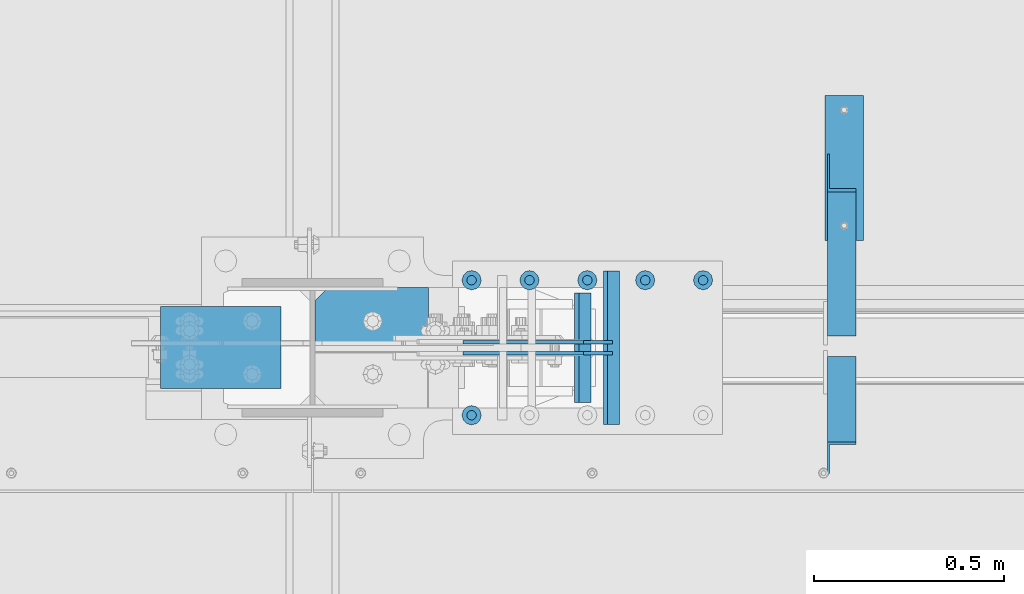
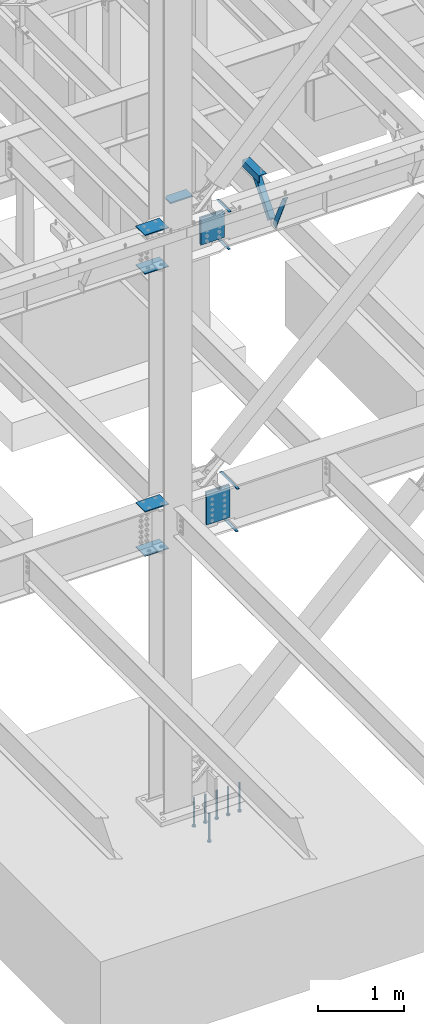
# One storey, part 835 of 1179: 20 beams, 2 members, 11 elements without a shape of their own.
"""IFC2X3 building model written with IfcOpenShell, lengths in millimetres."""

import ifcopenshell
import ifcopenshell.guid

model = None  # the IFC model being written
_history = None  # IfcOwnerHistory: only IFC2X3 demands one
_inside = {}  # id of a spatial element -> (the spatial element, [elements in it])
_under = {}  # id of a project, library or spatial element -> (it, [spatial elements below it])
_declared = {}  # id of a project -> (the project, [libraries it declares])
_typed = {}  # id of a type object -> (the type object, [elements of that type])
_made_of = {}  # id of a material, layer set ... -> (it, [elements and type objects made of it])


def new_model(schema):
    """Start an empty IFC model of exactly this schema.

    Asked for "IFC4X3", IfcOpenShell would pick the latest addendum, in which some entities
    have other attributes; the version numbers below select the first issue.
    IFC2X3 requires an IfcOwnerHistory on every rooted entity: one is made here for all.
    """
    global model, _history
    if schema == "IFC4X3":
        model = ifcopenshell.file(schema_version=(4, 3, 0, 0))
    else:
        model = ifcopenshell.file(schema=schema)
    _inside.clear()
    _under.clear()
    _declared.clear()
    _typed.clear()
    _made_of.clear()
    _history = None
    if model.schema == "IFC2X3":
        org = make("IfcOrganization", Name="unknown")
        user = make(
            "IfcPersonAndOrganization",
            ThePerson=make("IfcPerson", FamilyName="unknown"),
            TheOrganization=org,
        )
        app = make(
            "IfcApplication",
            ApplicationDeveloper=org,
            Version="unknown",
            ApplicationFullName="unknown",
            ApplicationIdentifier="unknown",
        )
        _history = make(
            "IfcOwnerHistory",
            OwningUser=user,
            OwningApplication=app,
            ChangeAction="ADDED",
            CreationDate=0,
        )
    return model


def make(cls, **values):
    """One entity of the class cls with the attributes given. An attribute that is None is left unset."""
    return model.create_entity(
        cls, **{name: value for name, value in values.items() if value is not None}
    )


def rooted(cls, **values):
    """An entity with a GlobalId (a new one), such as an element, a storey or a relation."""
    return make(cls, GlobalId=ifcopenshell.guid.new(), OwnerHistory=_history, **values)


def si_unit(unit_type, name, prefix=None):
    """IfcSIUnit, for example si_unit("LENGTHUNIT", "METRE", prefix="MILLI")."""
    return make("IfcSIUnit", UnitType=unit_type, Prefix=prefix, Name=name)


def assignment(units):
    """IfcUnitAssignment: the units of a project."""
    return None if units is None else make("IfcUnitAssignment", Units=units)


def point(xyz):
    """IfcCartesianPoint."""
    return None if xyz is None else make("IfcCartesianPoint", Coordinates=xyz)


def direction(xyz):
    """IfcDirection."""
    return None if xyz is None else make("IfcDirection", DirectionRatios=xyz)


def frame(location, z_axis=None, x_axis=None):
    """IfcAxis2Placement3D, a coordinate frame: its origin and axes. An axis left out is left unset."""
    return make(
        "IfcAxis2Placement3D",
        Location=point(location),
        Axis=direction(z_axis),
        RefDirection=direction(x_axis),
    )


def origin_with_axes():
    """The frame at (0, 0, 0) with the z axis (0, 0, 1) and the x axis (1, 0, 0) written out."""
    return frame((0.0, 0.0, 0.0), z_axis=(0.0, 0.0, 1.0), x_axis=(1.0, 0.0, 0.0))


def place(relative_to, where):
    """IfcLocalPlacement: puts the frame where relative to a parent placement (None: the world)."""
    return make(
        "IfcLocalPlacement", PlacementRelTo=relative_to, RelativePlacement=where
    )


def context(
    kind, dimensions, precision=None, world=None, true_north=None, identifier=None
):
    """IfcGeometricRepresentationContext, for example the 3D "Model" context."""
    return make(
        "IfcGeometricRepresentationContext",
        ContextIdentifier=identifier,
        ContextType=kind,
        CoordinateSpaceDimension=dimensions,
        Precision=precision,
        WorldCoordinateSystem=world,
        TrueNorth=true_north,
    )


def subcontext(parent, identifier, kind, view, scale=None):
    """IfcGeometricRepresentationSubContext, for example "Body" below "Model"."""
    return make(
        "IfcGeometricRepresentationSubContext",
        ContextIdentifier=identifier,
        ContextType=kind,
        ParentContext=parent,
        TargetScale=scale,
        TargetView=view,
    )


def project(units=None, contexts=None):
    """IfcProject with its units and contexts."""
    return rooted(
        "IfcProject",
        Name="project",
        RepresentationContexts=contexts,
        UnitsInContext=assignment(units),
    )


def spatial(cls, under=None, at=None, **own):
    """A site, building, storey or space (cls), placed at a placement, below another one or the project."""
    s = rooted(cls, ObjectPlacement=at, **own)
    if under is not None:
        _under.setdefault(under.id(), (under, []))[1].append(s)
    return s


def faces_of(points, faces, orient=None, outer=None):
    """IfcFace entities. A face is a list of loops; a loop is a list of indices into points, from 0.

    orient and outer hold one flag for each loop. By default every Orientation is true, the
    first loop of a face is its IfcFaceOuterBound and the others are IfcFaceBound.
    """
    made = []
    for i, loops in enumerate(faces):
        bounds = []
        for j, loop in enumerate(loops):
            is_outer = j == 0 if outer is None else outer[i][j]
            bounds.append(
                make(
                    "IfcFaceOuterBound" if is_outer else "IfcFaceBound",
                    Bound=make("IfcPolyLoop", Polygon=[points[k] for k in loop]),
                    Orientation=True if orient is None else orient[i][j],
                )
            )
        made.append(make("IfcFace", Bounds=bounds))
    return made


def faceted_brep(points, faces, orient=None, outer=None, voids=None):
    """IfcFacetedBrep: a solid bounded by flat faces; with voids (closed shells), ...WithVoids."""
    shared = [point(p) for p in points]
    hull = make("IfcClosedShell", CfsFaces=faces_of(shared, faces, orient, outer))
    if voids is None:
        return make("IfcFacetedBrep", Outer=hull)
    return make(
        "IfcFacetedBrepWithVoids",
        Outer=hull,
        Voids=[
            make(cls, CfsFaces=faces_of(shared, fs, o, b)) for cls, fs, o, b in voids
        ],
    )


def shape(context_of_items, identifier, shape_type, items):
    """IfcShapeRepresentation: the items that make up one representation, for example the "Body"."""
    return make(
        "IfcShapeRepresentation",
        ContextOfItems=context_of_items,
        RepresentationIdentifier=identifier,
        RepresentationType=shape_type,
        Items=items,
    )


def material(Name=None, Category=None):
    """IfcMaterial."""
    return make("IfcMaterial", Name=Name, Category=Category)


def made_of(thing, what):
    """Note that an element or type object is made of a material, layer set ...; save() writes the relation."""
    if what is not None:
        _made_of.setdefault(what.id(), (what, []))[1].append(thing)
    return thing


def type_object(cls, material=None, **own):
    """A type object (cls), such as IfcWallType, which elements share."""
    return made_of(rooted(cls, **own), material)


def element(
    cls,
    number,
    at=None,
    inside=None,
    cuts=None,
    type_object=None,
    material=None,
    context=None,
    identifier="Body",
    shape_type=None,
    held_by="IfcProductDefinitionShape",
    body=None,
    shapes=None,
    **own,
):
    """One element of the class cls, such as IfcWall. Its Tag is "e" and its number.

    at: its placement. inside: the storey or other place that contains it. cuts: it is an
    opening in that element (IfcRelVoidsElement). A single representation is given by context,
    identifier, shape_type and body (its items); several are given by shapes. held_by: the class
    of the entity that holds the representations. save() writes the other relations.
    """
    e = rooted(cls, Tag="e%d" % number, ObjectPlacement=at, **own)
    if body is not None:
        shapes = [shape(context, identifier, shape_type, body)]
    if shapes is not None:
        e.Representation = make(held_by, Representations=shapes)
    if inside is not None:
        _inside.setdefault(inside.id(), (inside, []))[1].append(e)
    if cuts is not None:
        rooted(
            "IfcRelVoidsElement", RelatingBuildingElement=cuts, RelatedOpeningElement=e
        )
    if type_object is not None:
        _typed.setdefault(type_object.id(), (type_object, []))[1].append(e)
    return made_of(e, material)


def aggregate(whole, parts):
    """IfcRelAggregates: a whole, such as a stair, and the parts it consists of."""
    return rooted("IfcRelAggregates", RelatingObject=whole, RelatedObjects=parts)


def save(model, path):
    """Write the relations noted so far, then the file.

    IfcRelAggregates (storeys below a building ...), IfcRelContainedInSpatialStructure (elements
    in a storey), IfcRelDefinesByType, IfcRelAssociatesMaterial and IfcRelDeclares: one each for
    every whole, place, type object, material and project.
    """
    for whole, parts in _under.values():
        aggregate(whole, parts)
    for where, things in _inside.values():
        rooted(
            "IfcRelContainedInSpatialStructure",
            RelatedElements=things,
            RelatingStructure=where,
        )
    for kind, things in _typed.values():
        rooted("IfcRelDefinesByType", RelatedObjects=things, RelatingType=kind)
    for what, things in _made_of.values():
        rooted("IfcRelAssociatesMaterial", RelatedObjects=things, RelatingMaterial=what)
    for by, libraries in _declared.values():
        rooted("IfcRelDeclares", RelatingContext=by, RelatedDefinitions=libraries)
    model.write(path)


model = new_model("IFC2X3")

# Units and contexts
model_context = context("Model", 3, precision=1e-05, world=origin_with_axes())
body_context = subcontext(model_context, "Body", "Model", "MODEL_VIEW")
ifc_project = project(units=[si_unit("LENGTHUNIT", "METRE", prefix="MILLI"), si_unit("AREAUNIT", "SQUARE_METRE"), si_unit("VOLUMEUNIT", "CUBIC_METRE"), si_unit("MASSUNIT", "GRAM", prefix="KILO"), si_unit("TIMEUNIT", "SECOND"), si_unit("PLANEANGLEUNIT", "RADIAN"), si_unit("SOLIDANGLEUNIT", "STERADIAN"), si_unit("THERMODYNAMICTEMPERATUREUNIT", "DEGREE_CELSIUS"), si_unit("LUMINOUSINTENSITYUNIT", "LUMEN")], contexts=[model_context])

# Site, building, storey
site_placement = place(None, origin_with_axes())
site = spatial("IfcSite", under=ifc_project, at=site_placement, CompositionType="ELEMENT")
building_placement = place(site_placement, origin_with_axes())
building = spatial("IfcBuilding", under=site, at=building_placement, Name="Undefined", CompositionType="ELEMENT")
storey_placement = place(building_placement, origin_with_axes())
storey = spatial("IfcBuildingStorey", under=building, at=storey_placement, Name="Undefined", CompositionType="ELEMENT", Elevation=0.0)

# Assembly, member
assembly_1_placement = place(storey_placement, origin_with_axes())
assembly_1 = element("IfcElementAssembly", 1, at=assembly_1_placement, inside=storey, Name="ANGLE", AssemblyPlace="NOTDEFINED", PredefinedType="RIGID_FRAME")
ifc_material_1 = material(Name="STEEL/A36")
member_type = type_object("IfcMemberType", Name="L3X3X1/4", PredefinedType="NOTDEFINED")
member_1_placement = place(assembly_1_placement, frame((9674.225, 27524.471875, 8013.7), z_axis=(0.0, 0.767781968046096, -0.640711206038465), x_axis=(0.0, -0.640711206038465, -0.767781968046095)))
member_1 = element("IfcMember", 2, at=member_1_placement, type_object=member_type, material=ifc_material_1, Name="ANGLE", ObjectType="L3X3X1/4", context=body_context, shape_type="Brep", body=[
    faceted_brep([(52.4707516281596, 38.1000000000004, -38.0999999999731), (-11.1178658854478, 38.1000000000004, 38.1000000000131), (644.538058171762, 38.1000000000004, 38.1000000006206), (644.538058171769, 38.1000000000004, -38.0999999994237), (-11.1178658854478, 31.75, 38.1000000000131), (644.538058171762, 31.75, 38.1000000006206), (47.171700168692, 31.75, -31.7499999999764), (644.538058171769, 31.75, -31.7499999994234), (47.171700168692, -38.1000000000004, -31.7499999999764), (644.538058171769, -38.1000000000004, -31.7499999994234), (52.4707516281596, -38.1000000000004, -38.0999999999731), (644.538058171769, -38.1000000000004, -38.0999999994237)], [[[0, 1, 2, 3]], [[1, 4, 5, 2]], [[4, 6, 7, 5]], [[6, 8, 9, 7]], [[8, 10, 11, 9]], [[10, 0, 3, 11]], [[5, 7, 9, 11, 3, 2]], [[10, 8, 6, 4, 1, 0]]]),
])
aggregate(assembly_1, [member_1])

assembly_2_placement = place(storey_placement, origin_with_axes())
assembly_2 = element("IfcElementAssembly", 3, at=assembly_2_placement, inside=storey, Name="ANGLE", AssemblyPlace="NOTDEFINED", PredefinedType="RIGID_FRAME")
member_2_placement = place(assembly_2_placement, frame((9674.225, 26993.5873387815, 7510.54092786574), z_axis=(0.0, -0.907857849951123, -0.419278098977426), x_axis=(0.0, -0.419278098977426, 0.907857849951123)))
member_2 = element("IfcMember", 4, at=member_2_placement, type_object=member_type, material=ifc_material_1, Name="ANGLE", ObjectType="L3X3X1/4", context=body_context, shape_type="Brep", body=[
    faceted_brep([(0.0, 38.0999999999985, -38.0999999999999), (0.0, 38.0999999999985, 38.0999999999999), (571.822524564442, 38.1000000000004, 38.0999999992528), (536.630901620703, 38.1000000000004, -38.1000000006316), (0.0, 31.75, 38.1000000000004), (571.822524564442, 31.75, 38.0999999992528), (0.0, 31.75, -31.75), (539.563536866016, 31.75, -31.7500000006403), (0.0, -38.0999999999985, -31.75), (539.563536866016, -38.1000000000004, -31.7500000006403), (0.0, -38.0999999999985, -38.0999999999999), (536.630901620703, -38.1000000000004, -38.1000000006316)], [[[0, 1, 2, 3]], [[1, 4, 5, 2]], [[4, 6, 7, 5]], [[6, 8, 9, 7]], [[8, 10, 11, 9]], [[10, 0, 3, 11]], [[5, 7, 9, 11, 3, 2]], [[10, 8, 6, 4, 1, 0]]]),
])
aggregate(assembly_2, [member_2])

# Assembly, beam
assembly_3_placement = place(storey_placement, origin_with_axes())
assembly_3 = element("IfcElementAssembly", 5, at=assembly_3_placement, inside=storey, Name="BEAM", AssemblyPlace="NOTDEFINED", PredefinedType="RIGID_FRAME")
ifc_material_2 = material(Name="STEEL/A572-GR.50")
beam_type_1 = type_object("IfcBeamType", PredefinedType="NOTDEFINED")
beam_1_placement = place(assembly_3_placement, frame((9002.72183475424, 27050.9999633791, 7459.6625), z_axis=(0.0, 1.0, 0.0), x_axis=(-1.0, 0.0, 0.0)))
beam_1 = element("IfcBeam", 6, at=beam_1_placement, type_object=beam_type_1, material=ifc_material_2, Name="PLATE", context=body_context, shape_type="Brep", body=[
    faceted_brep([(0.0, 4.76249999999982, -144.462500000001), (0.0, 4.76249999999982, 144.462500000001), (31.7500000000036, 4.76249999999982, 144.462500000001), (31.7500000000036, 4.76249999999982, -144.462500000001), (0.0, -4.76249999999982, 144.462500000001), (31.7500000000036, -4.76249999999982, 144.462500000001), (0.0, -4.76249999999982, -144.462500000001), (31.7500000000036, -4.76249999999982, -144.462500000001)], [[[0, 1, 2, 3]], [[1, 4, 5, 2]], [[4, 6, 7, 5]], [[6, 0, 3, 7]], [[5, 7, 3, 2]], [[6, 4, 1, 0]]]),
])

# Assembly, beams
assembly_4_placement = place(storey_placement, origin_with_axes())
assembly_4 = element("IfcElementAssembly", 7, at=assembly_4_placement, inside=storey, Name="BEAM", AssemblyPlace="NOTDEFINED", PredefinedType="RIGID_FRAME")
beam_2_placement = place(assembly_4_placement, frame((9078.515625, 27051.0000366209, 3475.0375), z_axis=(0.0, -1.0, 0.0), x_axis=(-1.0, 0.0, 0.0)))
beam_2 = element("IfcBeam", 8, at=beam_2_placement, type_object=beam_type_1, material=ifc_material_2, Name="PLATE", context=body_context, shape_type="Brep", body=[
    faceted_brep([(0.0, 4.76249999999982, -201.612499999999), (0.0, 4.76249999999982, 201.612499999999), (31.7500000000036, 4.76249999999982, 201.612499999999), (31.7500000000036, 4.76249999999982, -201.612499999999), (0.0, -4.76249999999982, 201.612499999999), (31.7500000000036, -4.76249999999982, 201.612499999999), (0.0, -4.76249999999982, -201.612499999999), (31.7500000000036, -4.76249999999982, -201.612499999999)], [[[0, 1, 2, 3]], [[1, 4, 5, 2]], [[4, 6, 7, 5]], [[6, 0, 3, 7]], [[5, 7, 3, 2]], [[6, 4, 1, 0]]]),
])
beam_3_placement = place(assembly_4_placement, frame((9089.628125, 27051.0000366209, 4073.128), z_axis=(0.0, -1.0, 0.0), x_axis=(-1.0, 0.0, 0.0)))
beam_3 = element("IfcBeam", 9, at=beam_3_placement, type_object=beam_type_1, material=ifc_material_2, Name="PLATE", context=body_context, shape_type="Brep", body=[
    faceted_brep([(0.0, 4.76249999999982, -201.612499999999), (0.0, 4.76249999999982, 201.612499999999), (31.7500000000036, 4.76249999999982, 201.612499999999), (31.7500000000036, 4.76249999999982, -201.612499999999), (0.0, -4.76249999999982, 201.612499999999), (31.7500000000036, -4.76249999999982, 201.612499999999), (0.0, -4.76249999999982, -201.612499999999), (31.7500000000036, -4.76249999999982, -201.612499999999)], [[[0, 1, 2, 3]], [[1, 4, 5, 2]], [[4, 6, 7, 5]], [[6, 0, 3, 7]], [[5, 7, 3, 2]], [[6, 4, 1, 0]]]),
])
aggregate(assembly_4, [beam_2, beam_3])

# Beam
beam_4_placement = place(assembly_3_placement, frame((9013.83391832986, 27050.9999633791, 7984.72549025941), z_axis=(0.0, 1.0, 0.0), x_axis=(-1.0, 0.0, 0.0)))
beam_4 = element("IfcBeam", 10, at=beam_4_placement, type_object=beam_type_1, material=ifc_material_2, Name="PLATE", context=body_context, shape_type="Brep", body=[
    faceted_brep([(0.0, 4.76249999999982, -144.462500000001), (0.0, 4.76249999999982, 144.462500000001), (31.7500000000036, 4.76249999999982, 144.462500000001), (31.7500000000036, 4.76249999999982, -144.462500000001), (0.0, -4.76249999999982, 144.462500000001), (31.7500000000036, -4.76249999999982, 144.462500000001), (0.0, -4.76249999999982, -144.462500000001), (31.7500000000036, -4.76249999999982, -144.462500000001)], [[[0, 1, 2, 3]], [[1, 4, 5, 2]], [[4, 6, 7, 5]], [[6, 0, 3, 7]], [[5, 7, 3, 2]], [[6, 4, 1, 0]]]),
])

aggregate(assembly_3, [beam_1, beam_4])

# Assembly, beams
assembly_5_placement = place(storey_placement, origin_with_axes())
assembly_5 = element("IfcElementAssembly", 11, at=assembly_5_placement, inside=storey, Name="COLUMN", AssemblyPlace="NOTDEFINED", PredefinedType="RIGID_FRAME")
beam_type_2 = type_object("IfcBeamType", PredefinedType="NOTDEFINED")
beam_5_placement = place(assembly_5_placement, frame((8197.85, 27051.0, 7473.94999999982), z_axis=(0.0, 1.0, 0.0), x_axis=(-1.0, 0.0, 0.0)))
beam_5 = element("IfcBeam", 12, at=beam_5_placement, type_object=beam_type_2, material=ifc_material_2, Name="PLATE", context=body_context, shape_type="Brep", body=[
    faceted_brep([(0.0, 6.35000000000036, -107.949999999997), (0.0, 6.35000000000036, 107.949999999997), (317.5, 6.35000000000036, 107.949999999997), (317.5, 6.35000000000036, -107.949999999997), (0.0, -6.35000000000036, 107.949999999997), (317.5, -6.35000000000036, 107.949999999997), (0.0, -6.35000000000036, -107.949999999997), (317.5, -6.35000000000036, -107.949999999997)], [[[0, 1, 2, 3]], [[1, 4, 5, 2]], [[4, 6, 7, 5]], [[6, 0, 3, 7]], [[5, 7, 3, 2]], [[6, 4, 1, 0]]]),
])
beam_6_placement = place(assembly_5_placement, frame((8197.85, 27051.0, 8020.04999999982), z_axis=(0.0, 1.0, 0.0), x_axis=(-1.0, 0.0, 0.0)))
beam_6 = element("IfcBeam", 13, at=beam_6_placement, type_object=beam_type_2, material=ifc_material_2, Name="PLATE", context=body_context, shape_type="Brep", body=[
    faceted_brep([(0.0, 6.35000000000036, -107.949999999997), (0.0, 6.35000000000036, 107.949999999997), (317.5, 6.35000000000036, 107.949999999997), (317.5, 6.35000000000036, -107.949999999997), (0.0, -6.35000000000036, 107.949999999997), (317.5, -6.35000000000036, 107.949999999997), (0.0, -6.35000000000036, -107.949999999997), (317.5, -6.35000000000036, -107.949999999997)], [[[0, 1, 2, 3]], [[1, 4, 5, 2]], [[4, 6, 7, 5]], [[6, 0, 3, 7]], [[5, 7, 3, 2]], [[6, 4, 1, 0]]]),
])
beam_7_placement = place(assembly_5_placement, frame((8197.85, 27051.0, 3482.97499626358), z_axis=(0.0, 1.0, 0.0), x_axis=(-1.0, 0.0, 0.0)))
beam_7 = element("IfcBeam", 14, at=beam_7_placement, type_object=beam_type_2, material=ifc_material_2, Name="PLATE", context=body_context, shape_type="Brep", body=[
    faceted_brep([(0.0, 6.35000000000036, -107.949999999997), (0.0, 6.35000000000036, 107.949999999997), (317.5, 6.35000000000036, 107.949999999997), (317.5, 6.35000000000036, -107.949999999997), (0.0, -6.35000000000036, 107.949999999997), (317.5, -6.35000000000036, 107.949999999997), (0.0, -6.35000000000036, -107.949999999997), (317.5, -6.35000000000036, -107.949999999997)], [[[0, 1, 2, 3]], [[1, 4, 5, 2]], [[4, 6, 7, 5]], [[6, 0, 3, 7]], [[5, 7, 3, 2]], [[6, 4, 1, 0]]]),
])
beam_8_placement = place(assembly_5_placement, frame((8197.85, 27051.0, 4108.45), z_axis=(0.0, 1.0, 0.0), x_axis=(-1.0, 0.0, 0.0)))
beam_8 = element("IfcBeam", 15, at=beam_8_placement, type_object=beam_type_2, material=ifc_material_2, Name="PLATE", context=body_context, shape_type="Brep", body=[
    faceted_brep([(0.0, 6.35000000000036, -107.949999999997), (0.0, 6.35000000000036, 107.949999999997), (317.5, 6.35000000000036, 107.949999999997), (317.5, 6.35000000000036, -107.949999999997), (0.0, -6.35000000000036, 107.949999999997), (317.5, -6.35000000000036, 107.949999999997), (0.0, -6.35000000000036, -107.949999999997), (317.5, -6.35000000000036, -107.949999999997)], [[[0, 1, 2, 3]], [[1, 4, 5, 2]], [[4, 6, 7, 5]], [[6, 0, 3, 7]], [[5, 7, 3, 2]], [[6, 4, 1, 0]]]),
])

# Assembly, beam
assembly_6_placement = place(storey_placement, origin_with_axes())
assembly_6 = element("IfcElementAssembly", 16, at=assembly_6_placement, inside=storey, Name="ANGLE", AssemblyPlace="NOTDEFINED", PredefinedType="RIGID_FRAME")
beam_type_3 = type_object("IfcBeamType", Name="L4X4X1/4", PredefinedType="NOTDEFINED")
beam_9_placement = place(assembly_6_placement, frame((9680.575, 27333.971887207, 7962.9), z_axis=(1.0, 0.0, 0.0), x_axis=(0.0, 1.0, 0.0)))
beam_9 = element("IfcBeam", 17, at=beam_9_placement, type_object=beam_type_3, material=ifc_material_1, Name="ANGLE", ObjectType="L4X4X1/4", context=body_context, shape_type="Brep", body=[
    faceted_brep([(1.90993887372315e-11, 50.8000000000002, -50.8000000000002), (1.90993887372315e-11, 50.8000000000002, 50.8000000000002), (381.0, 50.8000000000002, 50.7999999999993), (381.0, 50.8000000000002, -50.7999999999993), (0.0, 44.4500000000007, 50.8000000000002), (381.0, 44.4499999999998, 50.7999999999993), (0.0, 44.4500000000007, -44.4499999999998), (381.0, 44.4499999999998, -44.4500000000007), (0.0, -50.7999999999993, -44.4499999999998), (381.0, -50.8000000000002, -44.4500000000007), (-1.81898940354586e-11, -50.7999999999997, -50.8000000000002), (381.0, -50.8000000000002, -50.7999999999993)], [[[0, 1, 2, 3]], [[1, 4, 5, 2]], [[4, 6, 7, 5]], [[6, 8, 9, 7]], [[8, 10, 11, 9]], [[10, 0, 3, 11]], [[5, 7, 9, 11, 3, 2]], [[10, 8, 6, 4, 1, 0]]]),
])
aggregate(assembly_6, [beam_9])

assembly_7_placement = place(storey_placement, origin_with_axes())
assembly_7 = element("IfcElementAssembly", 18, at=assembly_7_placement, inside=storey, Name="PLATE", AssemblyPlace="NOTDEFINED", PredefinedType="RIGID_FRAME")
beam_type_4 = type_object("IfcBeamType", PredefinedType="NOTDEFINED")
beam_10_placement = place(assembly_7_placement, frame((9070.57812499999, 27036.7125, 3790.94999999941), z_axis=(0.0, 0.0, -1.0), x_axis=(-1.0, 0.0, 0.0)))
beam_10 = element("IfcBeam", 19, at=beam_10_placement, type_object=beam_type_4, material=ifc_material_2, Name="PLATE", context=body_context, shape_type="Brep", body=[
    faceted_brep([(0.0, 4.76250000000073, -228.6), (0.0, 4.76249999999999, 228.6), (317.5, 4.76250000000073, 228.6), (317.5, 4.76250000000073, -228.6), (0.0, -4.76249999999999, 228.6), (317.5, -4.76250000000073, 228.6), (0.0, -4.76250000000073, -228.6), (317.5, -4.76250000000073, -228.6)], [[[0, 1, 2, 3]], [[1, 4, 5, 2]], [[4, 6, 7, 5]], [[6, 0, 3, 7]], [[5, 7, 3, 2]], [[6, 4, 1, 0]]]),
])
aggregate(assembly_7, [beam_10])

assembly_8_placement = place(storey_placement, origin_with_axes())
assembly_8 = element("IfcElementAssembly", 20, at=assembly_8_placement, inside=storey, Name="PLATE", AssemblyPlace="NOTDEFINED", PredefinedType="RIGID_FRAME")
beam_11_placement = place(assembly_8_placement, frame((8753.07812499999, 27065.2872136118, 3790.94999999941), z_axis=(0.0, 0.0, -1.0), x_axis=(1.0, 0.0, 0.0)))
beam_11 = element("IfcBeam", 21, at=beam_11_placement, type_object=beam_type_4, material=ifc_material_2, Name="PLATE", context=body_context, shape_type="Brep", body=[
    faceted_brep([(0.0, 4.76250000000073, -228.6), (0.0, 4.76249999999999, 228.6), (317.5, 4.76250000000073, 228.6), (317.5, 4.76250000000073, -228.6), (0.0, -4.76249999999999, 228.6), (317.5, -4.76250000000073, 228.6), (0.0, -4.76250000000073, -228.6), (317.5, -4.76250000000073, -228.6)], [[[0, 1, 2, 3]], [[1, 4, 5, 2]], [[4, 6, 7, 5]], [[6, 0, 3, 7]], [[5, 7, 3, 2]], [[6, 4, 1, 0]]]),
])
aggregate(assembly_8, [beam_11])

assembly_9_placement = place(storey_placement, origin_with_axes())
assembly_9 = element("IfcElementAssembly", 22, at=assembly_9_placement, inside=storey, Name="PLATE", AssemblyPlace="NOTDEFINED", PredefinedType="RIGID_FRAME")
beam_12_placement = place(assembly_9_placement, frame((8677.28402946726, 27036.7127863882, 7739.06051692827), z_axis=(0.0, 0.0, -1.0), x_axis=(1.0, 0.0, 0.0)))
beam_12 = element("IfcBeam", 23, at=beam_12_placement, type_object=beam_type_4, material=ifc_material_2, Name="PLATE", context=body_context, shape_type="Brep", body=[
    faceted_brep([(0.0, 4.76249999999709, -190.5), (0.0, 4.76249999999709, 190.5), (317.499999999995, 4.76250000000073, 190.500000000051), (317.500000000042, 4.76250000000073, -190.499999999973), (0.0, -4.76249999999709, 190.5), (317.499999999995, -4.76250000000073, 190.500000000051), (0.0, -4.76249999999709, -190.5), (317.500000000042, -4.76250000000073, -190.499999999973)], [[[0, 1, 2, 3]], [[1, 4, 5, 2]], [[4, 6, 7, 5]], [[6, 0, 3, 7]], [[5, 7, 3, 2]], [[6, 4, 1, 0]]]),
])
aggregate(assembly_9, [beam_12])

assembly_10_placement = place(storey_placement, origin_with_axes())
assembly_10 = element("IfcElementAssembly", 24, at=assembly_10_placement, inside=storey, Name="PLATE", AssemblyPlace="NOTDEFINED", PredefinedType="RIGID_FRAME")
beam_13_placement = place(assembly_10_placement, frame((8994.78391818764, 27065.2872136118, 7739.06249999982), z_axis=(0.0, 0.0, -1.0), x_axis=(-1.0, 0.0, 0.0)))
beam_13 = element("IfcBeam", 25, at=beam_13_placement, type_object=beam_type_4, material=ifc_material_2, Name="PLATE", context=body_context, shape_type="Brep", body=[
    faceted_brep([(0.0, 4.76249999999709, -190.5), (0.0, 4.76249999999709, 190.5), (317.499999999995, 4.76250000000073, 190.500000000051), (317.500000000042, 4.76250000000073, -190.499999999973), (0.0, -4.76249999999709, 190.5), (317.499999999995, -4.76250000000073, 190.500000000051), (0.0, -4.76249999999709, -190.5), (317.500000000042, -4.76250000000073, -190.499999999973)], [[[0, 1, 2, 3]], [[1, 4, 5, 2]], [[4, 6, 7, 5]], [[6, 0, 3, 7]], [[5, 7, 3, 2]], [[6, 4, 1, 0]]]),
])
aggregate(assembly_10, [beam_13])

# Beam
beam_type_5 = type_object("IfcBeamType", PredefinedType="NOTDEFINED")
beam_14_placement = place(assembly_5_placement, frame((8585.58933097975, 27135.9315, 8260.2854161103), z_axis=(0.0, 1.0, 0.0), x_axis=(-1.0, 0.0, 0.0)))
beam_14 = element("IfcBeam", 26, at=beam_14_placement, type_object=beam_type_5, material=ifc_material_2, Name="PLATE", context=body_context, shape_type="Brep", body=[
    faceted_brep([(298.839332807032, 9.52499999999964, 38.8940000000002), (263.914332807033, 9.52499999999964, 73.8189999999995), (263.914332807033, -9.52499999999964, 73.8189999999995), (298.839332807032, -9.52499999999964, 38.8940000000002), (298.839332807032, 9.52499999999964, -73.8189999999995), (0.0, 9.52499999999964, -73.8189999999995), (0.0, 9.52499999999964, 73.8189999999995), (0.0, -9.52499999999964, 73.8189999999995), (0.0, -9.52499999999964, -73.8189999999995), (298.839332807032, -9.52499999999964, -73.8189999999995)], [[[0, 1, 2, 3]], [[4, 5, 6, 1, 0]], [[6, 7, 2, 1]], [[7, 8, 9, 3, 2]], [[8, 5, 4, 9]], [[9, 4, 0, 3]], [[8, 7, 6, 5]]]),
])

aggregate(assembly_5, [beam_14, beam_5, beam_6, beam_7, beam_8])

# Assembly, beams
assembly_11_placement = place(storey_placement, origin_with_axes())
assembly_11 = element("IfcElementAssembly", 27, at=assembly_11_placement, inside=storey, Name="EMBED_PLATE", AssemblyPlace="NOTDEFINED", PredefinedType="RIGID_FRAME")
ifc_material_3 = material(Name="STEEL/A108")
beam_type_6 = type_object("IfcBeamType", Name="STUD_1-DIA", PredefinedType="NOTDEFINED")
beam_15_placement = place(assembly_11_placement, frame((8699.5, 27228.8, -393.700000000001), z_axis=(1.0, 0.0, 0.0), x_axis=(0.0, 0.0, -1.0)))
beam_15 = element("IfcBeam", 28, at=beam_15_placement, type_object=beam_type_6, material=ifc_material_3, Name="STUD", ObjectType="STUD_1-DIA", context=body_context, shape_type="Brep", body=[
    faceted_brep([(0.0, -12.7, 0.0), (0.0, -11.0, -6.34999990463257), (382.016, -11.0, -6.34999990463257), (382.016, -12.6999998092651, 0.0), (0.0, -6.34999990463257, -11.0), (382.016, -6.34999990463257, -11.0), (0.0, 0.0, -12.6999998092651), (382.016, 0.0, -12.6999998092651), (0.0, 6.34999990463257, -11.0), (382.016, 6.34999990463257, -11.0), (0.0, 11.0, -6.34999990463257), (382.016, 11.0, -6.34999990463257), (0.0, 12.7, 0.0), (382.016, 12.6999998092651, 0.0), (0.0, 11.0, 6.34999990463257), (382.016, 11.0, 6.34999990463257), (0.0, 6.34999990463257, 11.0), (382.016, 6.34999990463257, 11.0), (0.0, 0.0, 12.6999998092651), (382.016, 0.0, 12.6999998092651), (0.0, -6.34999990463257, 11.0), (382.016, -6.34999990463257, 11.0), (0.0, -11.0, 6.34999990463257), (382.016, -11.0, 6.34999990463257), (386.08, -22.0, -12.6999998092651), (386.08, -25.3999996185303, 0.0), (386.08, -12.6999998092651, -22.0), (386.08, 0.0, -25.3999996185303), (386.08, 12.6999998092651, -22.0), (386.08, 22.0, -12.6999998092651), (386.08, 25.3999996185303, 0.0), (386.08, 22.0, 12.6999998092651), (386.08, 12.6999998092651, 22.0), (386.08, 0.0, 25.3999996185303), (386.08, -12.6999998092651, 22.0), (386.08, -22.0, 12.6999998092651), (406.4, -22.0, -12.6999998092651), (406.4, -25.3999996185303, 0.0), (406.4, -12.6999998092651, -22.0), (406.4, 0.0, -25.3999996185303), (406.4, 12.6999998092651, -22.0), (406.4, 22.0, -12.6999998092651), (406.4, 25.3999996185303, 0.0), (406.4, 22.0, 12.6999998092651), (406.4, 12.6999998092651, 22.0), (406.4, 0.0, 25.3999996185303), (406.4, -12.6999998092651, 22.0), (406.4, -22.0, 12.6999998092651)], [[[0, 1, 2, 3]], [[1, 4, 5, 2]], [[4, 6, 7, 5]], [[6, 8, 9, 7]], [[8, 10, 11, 9]], [[10, 12, 13, 11]], [[12, 14, 15, 13]], [[14, 16, 17, 15]], [[16, 18, 19, 17]], [[18, 20, 21, 19]], [[20, 22, 23, 21]], [[22, 0, 3, 23]], [[22, 20, 18, 16, 14, 12, 10, 8, 6, 4, 1, 0]], [[3, 2, 24, 25]], [[2, 5, 26, 24]], [[5, 7, 27, 26]], [[7, 9, 28, 27]], [[9, 11, 29, 28]], [[11, 13, 30, 29]], [[13, 15, 31, 30]], [[15, 17, 32, 31]], [[17, 19, 33, 32]], [[19, 21, 34, 33]], [[21, 23, 35, 34]], [[23, 3, 25, 35]], [[25, 24, 36, 37]], [[24, 26, 38, 36]], [[26, 27, 39, 38]], [[27, 28, 40, 39]], [[28, 29, 41, 40]], [[29, 30, 42, 41]], [[30, 31, 43, 42]], [[31, 32, 44, 43]], [[32, 33, 45, 44]], [[33, 34, 46, 45]], [[34, 35, 47, 46]], [[35, 25, 37, 47]], [[38, 39, 40, 41, 42, 43, 44, 45, 46, 47, 37, 36]]]),
])
beam_16_placement = place(assembly_11_placement, frame((8699.5, 26873.2, -393.700000000001), z_axis=(1.0, 0.0, 0.0), x_axis=(0.0, 0.0, -1.0)))
beam_16 = element("IfcBeam", 29, at=beam_16_placement, type_object=beam_type_6, material=ifc_material_3, Name="STUD", ObjectType="STUD_1-DIA", context=body_context, shape_type="Brep", body=[
    faceted_brep([(0.0, -12.7, 0.0), (0.0, -11.0, -6.34999990463257), (382.016, -11.0, -6.34999990463257), (382.016, -12.6999998092651, 0.0), (0.0, -6.34999990463257, -11.0), (382.016, -6.34999990463257, -11.0), (0.0, 0.0, -12.6999998092651), (382.016, 0.0, -12.6999998092651), (0.0, 6.34999990463257, -11.0), (382.016, 6.34999990463257, -11.0), (0.0, 11.0, -6.34999990463257), (382.016, 11.0, -6.34999990463257), (0.0, 12.7, 0.0), (382.016, 12.6999998092651, 0.0), (0.0, 11.0, 6.34999990463257), (382.016, 11.0, 6.34999990463257), (0.0, 6.34999990463257, 11.0), (382.016, 6.34999990463257, 11.0), (0.0, 0.0, 12.6999998092651), (382.016, 0.0, 12.6999998092651), (0.0, -6.34999990463257, 11.0), (382.016, -6.34999990463257, 11.0), (0.0, -11.0, 6.34999990463257), (382.016, -11.0, 6.34999990463257), (386.08, -22.0, -12.6999998092651), (386.08, -25.3999996185303, 0.0), (386.08, -12.6999998092651, -22.0), (386.08, 0.0, -25.3999996185303), (386.08, 12.6999998092651, -22.0), (386.08, 22.0, -12.6999998092651), (386.08, 25.3999996185303, 0.0), (386.08, 22.0, 12.6999998092651), (386.08, 12.6999998092651, 22.0), (386.08, 0.0, 25.3999996185303), (386.08, -12.6999998092651, 22.0), (386.08, -22.0, 12.6999998092651), (406.4, -22.0, -12.6999998092651), (406.4, -25.3999996185303, 0.0), (406.4, -12.6999998092651, -22.0), (406.4, 0.0, -25.3999996185303), (406.4, 12.6999998092651, -22.0), (406.4, 22.0, -12.6999998092651), (406.4, 25.3999996185303, 0.0), (406.4, 22.0, 12.6999998092651), (406.4, 12.6999998092651, 22.0), (406.4, 0.0, 25.3999996185303), (406.4, -12.6999998092651, 22.0), (406.4, -22.0, 12.6999998092651)], [[[0, 1, 2, 3]], [[1, 4, 5, 2]], [[4, 6, 7, 5]], [[6, 8, 9, 7]], [[8, 10, 11, 9]], [[10, 12, 13, 11]], [[12, 14, 15, 13]], [[14, 16, 17, 15]], [[16, 18, 19, 17]], [[18, 20, 21, 19]], [[20, 22, 23, 21]], [[22, 0, 3, 23]], [[22, 20, 18, 16, 14, 12, 10, 8, 6, 4, 1, 0]], [[3, 2, 24, 25]], [[2, 5, 26, 24]], [[5, 7, 27, 26]], [[7, 9, 28, 27]], [[9, 11, 29, 28]], [[11, 13, 30, 29]], [[13, 15, 31, 30]], [[15, 17, 32, 31]], [[17, 19, 33, 32]], [[19, 21, 34, 33]], [[21, 23, 35, 34]], [[23, 3, 25, 35]], [[25, 24, 36, 37]], [[24, 26, 38, 36]], [[26, 27, 39, 38]], [[27, 28, 40, 39]], [[28, 29, 41, 40]], [[29, 30, 42, 41]], [[30, 31, 43, 42]], [[31, 32, 44, 43]], [[32, 33, 45, 44]], [[33, 34, 46, 45]], [[34, 35, 47, 46]], [[35, 25, 37, 47]], [[38, 39, 40, 41, 42, 43, 44, 45, 46, 47, 37, 36]]]),
])
beam_17_placement = place(assembly_11_placement, frame((9309.1, 27228.8, -393.700000000001), z_axis=(1.0, 0.0, 0.0), x_axis=(0.0, 0.0, -1.0)))
beam_17 = element("IfcBeam", 30, at=beam_17_placement, type_object=beam_type_6, material=ifc_material_3, Name="STUD", ObjectType="STUD_1-DIA", context=body_context, shape_type="Brep", body=[
    faceted_brep([(0.0, -12.7, 0.0), (0.0, -11.0, -6.34999990463257), (382.016, -11.0, -6.34999990463257), (382.016, -12.6999998092651, 0.0), (0.0, -6.34999990463257, -11.0), (382.016, -6.34999990463257, -11.0), (0.0, 0.0, -12.6999998092651), (382.016, 0.0, -12.6999998092651), (0.0, 6.34999990463257, -11.0), (382.016, 6.34999990463257, -11.0), (0.0, 11.0, -6.34999990463257), (382.016, 11.0, -6.34999990463257), (0.0, 12.7, 0.0), (382.016, 12.6999998092651, 0.0), (0.0, 11.0, 6.34999990463257), (382.016, 11.0, 6.34999990463257), (0.0, 6.34999990463257, 11.0), (382.016, 6.34999990463257, 11.0), (0.0, 0.0, 12.6999998092651), (382.016, 0.0, 12.6999998092651), (0.0, -6.34999990463257, 11.0), (382.016, -6.34999990463257, 11.0), (0.0, -11.0, 6.34999990463257), (382.016, -11.0, 6.34999990463257), (386.08, -22.0, -12.6999998092651), (386.08, -25.3999996185303, 0.0), (386.08, -12.6999998092651, -22.0), (386.08, 0.0, -25.3999996185303), (386.08, 12.6999998092651, -22.0), (386.08, 22.0, -12.6999998092651), (386.08, 25.3999996185303, 0.0), (386.08, 22.0, 12.6999998092651), (386.08, 12.6999998092651, 22.0), (386.08, 0.0, 25.3999996185303), (386.08, -12.6999998092651, 22.0), (386.08, -22.0, 12.6999998092651), (406.4, -22.0, -12.6999998092651), (406.4, -25.3999996185303, 0.0), (406.4, -12.6999998092651, -22.0), (406.4, 0.0, -25.3999996185303), (406.4, 12.6999998092651, -22.0), (406.4, 22.0, -12.6999998092651), (406.4, 25.3999996185303, 0.0), (406.4, 22.0, 12.6999998092651), (406.4, 12.6999998092651, 22.0), (406.4, 0.0, 25.3999996185303), (406.4, -12.6999998092651, 22.0), (406.4, -22.0, 12.6999998092651)], [[[0, 1, 2, 3]], [[1, 4, 5, 2]], [[4, 6, 7, 5]], [[6, 8, 9, 7]], [[8, 10, 11, 9]], [[10, 12, 13, 11]], [[12, 14, 15, 13]], [[14, 16, 17, 15]], [[16, 18, 19, 17]], [[18, 20, 21, 19]], [[20, 22, 23, 21]], [[22, 0, 3, 23]], [[22, 20, 18, 16, 14, 12, 10, 8, 6, 4, 1, 0]], [[3, 2, 24, 25]], [[2, 5, 26, 24]], [[5, 7, 27, 26]], [[7, 9, 28, 27]], [[9, 11, 29, 28]], [[11, 13, 30, 29]], [[13, 15, 31, 30]], [[15, 17, 32, 31]], [[17, 19, 33, 32]], [[19, 21, 34, 33]], [[21, 23, 35, 34]], [[23, 3, 25, 35]], [[25, 24, 36, 37]], [[24, 26, 38, 36]], [[26, 27, 39, 38]], [[27, 28, 40, 39]], [[28, 29, 41, 40]], [[29, 30, 42, 41]], [[30, 31, 43, 42]], [[31, 32, 44, 43]], [[32, 33, 45, 44]], [[33, 34, 46, 45]], [[34, 35, 47, 46]], [[35, 25, 37, 47]], [[38, 39, 40, 41, 42, 43, 44, 45, 46, 47, 37, 36]]]),
])
beam_18_placement = place(assembly_11_placement, frame((9156.7, 27228.8, -393.700000000001), z_axis=(1.0, 0.0, 0.0), x_axis=(0.0, 0.0, -1.0)))
beam_18 = element("IfcBeam", 31, at=beam_18_placement, type_object=beam_type_6, material=ifc_material_3, Name="STUD", ObjectType="STUD_1-DIA", context=body_context, shape_type="Brep", body=[
    faceted_brep([(0.0, -12.7, 0.0), (0.0, -11.0, -6.34999990463257), (382.016, -11.0, -6.34999990463257), (382.016, -12.6999998092651, 0.0), (0.0, -6.34999990463257, -11.0), (382.016, -6.34999990463257, -11.0), (0.0, 0.0, -12.6999998092651), (382.016, 0.0, -12.6999998092651), (0.0, 6.34999990463257, -11.0), (382.016, 6.34999990463257, -11.0), (0.0, 11.0, -6.34999990463257), (382.016, 11.0, -6.34999990463257), (0.0, 12.7, 0.0), (382.016, 12.6999998092651, 0.0), (0.0, 11.0, 6.34999990463257), (382.016, 11.0, 6.34999990463257), (0.0, 6.34999990463257, 11.0), (382.016, 6.34999990463257, 11.0), (0.0, 0.0, 12.6999998092651), (382.016, 0.0, 12.6999998092651), (0.0, -6.34999990463257, 11.0), (382.016, -6.34999990463257, 11.0), (0.0, -11.0, 6.34999990463257), (382.016, -11.0, 6.34999990463257), (386.08, -22.0, -12.6999998092651), (386.08, -25.3999996185303, 0.0), (386.08, -12.6999998092651, -22.0), (386.08, 0.0, -25.3999996185303), (386.08, 12.6999998092651, -22.0), (386.08, 22.0, -12.6999998092651), (386.08, 25.3999996185303, 0.0), (386.08, 22.0, 12.6999998092651), (386.08, 12.6999998092651, 22.0), (386.08, 0.0, 25.3999996185303), (386.08, -12.6999998092651, 22.0), (386.08, -22.0, 12.6999998092651), (406.4, -22.0, -12.6999998092651), (406.4, -25.3999996185303, 0.0), (406.4, -12.6999998092651, -22.0), (406.4, 0.0, -25.3999996185303), (406.4, 12.6999998092651, -22.0), (406.4, 22.0, -12.6999998092651), (406.4, 25.3999996185303, 0.0), (406.4, 22.0, 12.6999998092651), (406.4, 12.6999998092651, 22.0), (406.4, 0.0, 25.3999996185303), (406.4, -12.6999998092651, 22.0), (406.4, -22.0, 12.6999998092651)], [[[0, 1, 2, 3]], [[1, 4, 5, 2]], [[4, 6, 7, 5]], [[6, 8, 9, 7]], [[8, 10, 11, 9]], [[10, 12, 13, 11]], [[12, 14, 15, 13]], [[14, 16, 17, 15]], [[16, 18, 19, 17]], [[18, 20, 21, 19]], [[20, 22, 23, 21]], [[22, 0, 3, 23]], [[22, 20, 18, 16, 14, 12, 10, 8, 6, 4, 1, 0]], [[3, 2, 24, 25]], [[2, 5, 26, 24]], [[5, 7, 27, 26]], [[7, 9, 28, 27]], [[9, 11, 29, 28]], [[11, 13, 30, 29]], [[13, 15, 31, 30]], [[15, 17, 32, 31]], [[17, 19, 33, 32]], [[19, 21, 34, 33]], [[21, 23, 35, 34]], [[23, 3, 25, 35]], [[25, 24, 36, 37]], [[24, 26, 38, 36]], [[26, 27, 39, 38]], [[27, 28, 40, 39]], [[28, 29, 41, 40]], [[29, 30, 42, 41]], [[30, 31, 43, 42]], [[31, 32, 44, 43]], [[32, 33, 45, 44]], [[33, 34, 46, 45]], [[34, 35, 47, 46]], [[35, 25, 37, 47]], [[38, 39, 40, 41, 42, 43, 44, 45, 46, 47, 37, 36]]]),
])
beam_19_placement = place(assembly_11_placement, frame((9004.3, 27228.8, -393.700000000001), z_axis=(1.0, 0.0, 0.0), x_axis=(0.0, 0.0, -1.0)))
beam_19 = element("IfcBeam", 32, at=beam_19_placement, type_object=beam_type_6, material=ifc_material_3, Name="STUD", ObjectType="STUD_1-DIA", context=body_context, shape_type="Brep", body=[
    faceted_brep([(0.0, -12.7, 0.0), (0.0, -11.0, -6.34999990463257), (382.016, -11.0, -6.34999990463257), (382.016, -12.6999998092651, 0.0), (0.0, -6.34999990463257, -11.0), (382.016, -6.34999990463257, -11.0), (0.0, 0.0, -12.6999998092651), (382.016, 0.0, -12.6999998092651), (0.0, 6.34999990463257, -11.0), (382.016, 6.34999990463257, -11.0), (0.0, 11.0, -6.34999990463257), (382.016, 11.0, -6.34999990463257), (0.0, 12.7, 0.0), (382.016, 12.6999998092651, 0.0), (0.0, 11.0, 6.34999990463257), (382.016, 11.0, 6.34999990463257), (0.0, 6.34999990463257, 11.0), (382.016, 6.34999990463257, 11.0), (0.0, 0.0, 12.6999998092651), (382.016, 0.0, 12.6999998092651), (0.0, -6.34999990463257, 11.0), (382.016, -6.34999990463257, 11.0), (0.0, -11.0, 6.34999990463257), (382.016, -11.0, 6.34999990463257), (386.08, -22.0, -12.6999998092651), (386.08, -25.3999996185303, 0.0), (386.08, -12.6999998092651, -22.0), (386.08, 0.0, -25.3999996185303), (386.08, 12.6999998092651, -22.0), (386.08, 22.0, -12.6999998092651), (386.08, 25.3999996185303, 0.0), (386.08, 22.0, 12.6999998092651), (386.08, 12.6999998092651, 22.0), (386.08, 0.0, 25.3999996185303), (386.08, -12.6999998092651, 22.0), (386.08, -22.0, 12.6999998092651), (406.4, -22.0, -12.6999998092651), (406.4, -25.3999996185303, 0.0), (406.4, -12.6999998092651, -22.0), (406.4, 0.0, -25.3999996185303), (406.4, 12.6999998092651, -22.0), (406.4, 22.0, -12.6999998092651), (406.4, 25.3999996185303, 0.0), (406.4, 22.0, 12.6999998092651), (406.4, 12.6999998092651, 22.0), (406.4, 0.0, 25.3999996185303), (406.4, -12.6999998092651, 22.0), (406.4, -22.0, 12.6999998092651)], [[[0, 1, 2, 3]], [[1, 4, 5, 2]], [[4, 6, 7, 5]], [[6, 8, 9, 7]], [[8, 10, 11, 9]], [[10, 12, 13, 11]], [[12, 14, 15, 13]], [[14, 16, 17, 15]], [[16, 18, 19, 17]], [[18, 20, 21, 19]], [[20, 22, 23, 21]], [[22, 0, 3, 23]], [[22, 20, 18, 16, 14, 12, 10, 8, 6, 4, 1, 0]], [[3, 2, 24, 25]], [[2, 5, 26, 24]], [[5, 7, 27, 26]], [[7, 9, 28, 27]], [[9, 11, 29, 28]], [[11, 13, 30, 29]], [[13, 15, 31, 30]], [[15, 17, 32, 31]], [[17, 19, 33, 32]], [[19, 21, 34, 33]], [[21, 23, 35, 34]], [[23, 3, 25, 35]], [[25, 24, 36, 37]], [[24, 26, 38, 36]], [[26, 27, 39, 38]], [[27, 28, 40, 39]], [[28, 29, 41, 40]], [[29, 30, 42, 41]], [[30, 31, 43, 42]], [[31, 32, 44, 43]], [[32, 33, 45, 44]], [[33, 34, 46, 45]], [[34, 35, 47, 46]], [[35, 25, 37, 47]], [[38, 39, 40, 41, 42, 43, 44, 45, 46, 47, 37, 36]]]),
])
beam_20_placement = place(assembly_11_placement, frame((8851.9, 27228.8, -393.700000000001), z_axis=(1.0, 0.0, 0.0), x_axis=(0.0, 0.0, -1.0)))
beam_20 = element("IfcBeam", 33, at=beam_20_placement, type_object=beam_type_6, material=ifc_material_3, Name="STUD", ObjectType="STUD_1-DIA", context=body_context, shape_type="Brep", body=[
    faceted_brep([(0.0, -12.7, 0.0), (0.0, -11.0, -6.34999990463257), (382.016, -11.0, -6.34999990463257), (382.016, -12.6999998092651, 0.0), (0.0, -6.34999990463257, -11.0), (382.016, -6.34999990463257, -11.0), (0.0, 0.0, -12.6999998092651), (382.016, 0.0, -12.6999998092651), (0.0, 6.34999990463257, -11.0), (382.016, 6.34999990463257, -11.0), (0.0, 11.0, -6.34999990463257), (382.016, 11.0, -6.34999990463257), (0.0, 12.7, 0.0), (382.016, 12.6999998092651, 0.0), (0.0, 11.0, 6.34999990463257), (382.016, 11.0, 6.34999990463257), (0.0, 6.34999990463257, 11.0), (382.016, 6.34999990463257, 11.0), (0.0, 0.0, 12.6999998092651), (382.016, 0.0, 12.6999998092651), (0.0, -6.34999990463257, 11.0), (382.016, -6.34999990463257, 11.0), (0.0, -11.0, 6.34999990463257), (382.016, -11.0, 6.34999990463257), (386.08, -22.0, -12.6999998092651), (386.08, -25.3999996185303, 0.0), (386.08, -12.6999998092651, -22.0), (386.08, 0.0, -25.3999996185303), (386.08, 12.6999998092651, -22.0), (386.08, 22.0, -12.6999998092651), (386.08, 25.3999996185303, 0.0), (386.08, 22.0, 12.6999998092651), (386.08, 12.6999998092651, 22.0), (386.08, 0.0, 25.3999996185303), (386.08, -12.6999998092651, 22.0), (386.08, -22.0, 12.6999998092651), (406.4, -22.0, -12.6999998092651), (406.4, -25.3999996185303, 0.0), (406.4, -12.6999998092651, -22.0), (406.4, 0.0, -25.3999996185303), (406.4, 12.6999998092651, -22.0), (406.4, 22.0, -12.6999998092651), (406.4, 25.3999996185303, 0.0), (406.4, 22.0, 12.6999998092651), (406.4, 12.6999998092651, 22.0), (406.4, 0.0, 25.3999996185303), (406.4, -12.6999998092651, 22.0), (406.4, -22.0, 12.6999998092651)], [[[0, 1, 2, 3]], [[1, 4, 5, 2]], [[4, 6, 7, 5]], [[6, 8, 9, 7]], [[8, 10, 11, 9]], [[10, 12, 13, 11]], [[12, 14, 15, 13]], [[14, 16, 17, 15]], [[16, 18, 19, 17]], [[18, 20, 21, 19]], [[20, 22, 23, 21]], [[22, 0, 3, 23]], [[22, 20, 18, 16, 14, 12, 10, 8, 6, 4, 1, 0]], [[3, 2, 24, 25]], [[2, 5, 26, 24]], [[5, 7, 27, 26]], [[7, 9, 28, 27]], [[9, 11, 29, 28]], [[11, 13, 30, 29]], [[13, 15, 31, 30]], [[15, 17, 32, 31]], [[17, 19, 33, 32]], [[19, 21, 34, 33]], [[21, 23, 35, 34]], [[23, 3, 25, 35]], [[25, 24, 36, 37]], [[24, 26, 38, 36]], [[26, 27, 39, 38]], [[27, 28, 40, 39]], [[28, 29, 41, 40]], [[29, 30, 42, 41]], [[30, 31, 43, 42]], [[31, 32, 44, 43]], [[32, 33, 45, 44]], [[33, 34, 46, 45]], [[34, 35, 47, 46]], [[35, 25, 37, 47]], [[38, 39, 40, 41, 42, 43, 44, 45, 46, 47, 37, 36]]]),
])
aggregate(assembly_11, [beam_15, beam_16, beam_17, beam_18, beam_19, beam_20])

save(model, "model.ifc")
